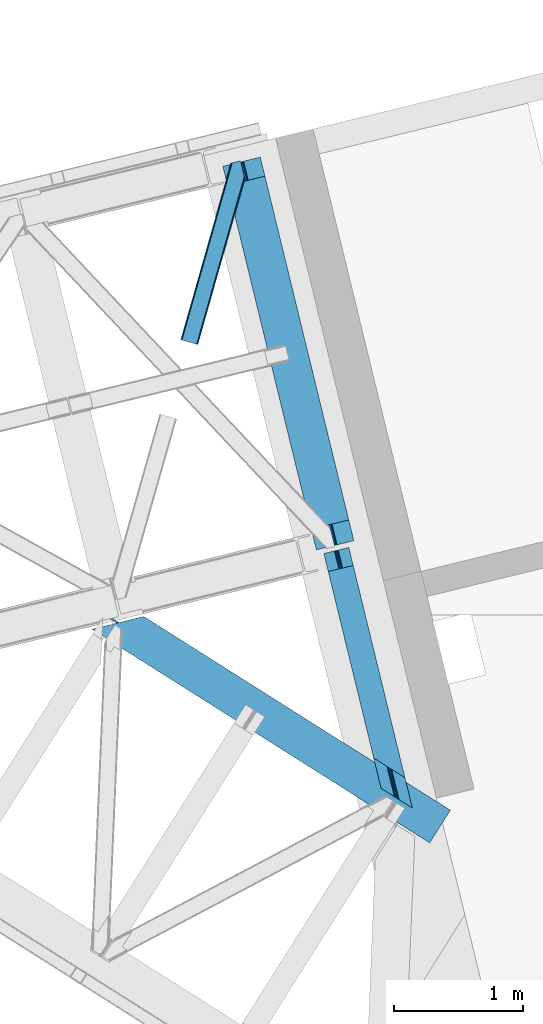
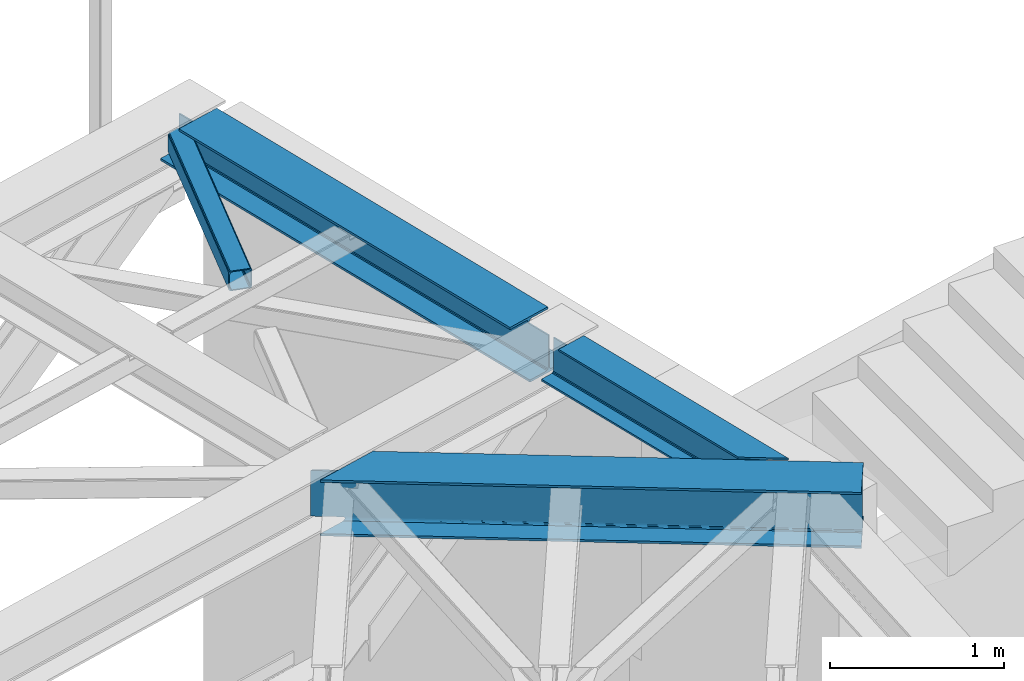
# One storey, part 62 of 66: 3 beams, 1 member.
"""IFC4 building model written with IfcOpenShell, lengths in millimetres."""

from ifc_helpers import new_model, entity, si_unit, converted_unit, derived_unit, direction, frame, origin, place, context, subcontext, project, spatial, triangles, polygons, material, type_object, element, save


model = new_model("IFC4")

# Units and contexts
model_context = context("Model", 3, precision=0.01, world=origin(), true_north=direction((6.12303176911189e-17, 1.0)))
plan_context = context("Plan", 3, precision=0.01, world=origin(), true_north=direction((6.12303176911189e-17, 1.0)))
body_context = subcontext(model_context, "Body", "Model", "MODEL_VIEW")
ifc_project = project(units=[si_unit("LENGTHUNIT", "METRE", prefix="MILLI"), si_unit("AREAUNIT", "SQUARE_METRE"), si_unit("VOLUMEUNIT", "CUBIC_METRE"), converted_unit("PLANEANGLEUNIT", "DEGREE", entity("IfcRatioMeasure", 0.0174532925199433), si_unit("PLANEANGLEUNIT", "RADIAN"), dimensions=[0, 0, 0, 0, 0, 0, 0]), si_unit("MASSUNIT", "GRAM", prefix="KILO"), derived_unit("MASSDENSITYUNIT", [(si_unit("MASSUNIT", "GRAM", prefix="KILO"), 1), (si_unit("LENGTHUNIT", "METRE"), -3)]), derived_unit("MOMENTOFINERTIAUNIT", [(si_unit("LENGTHUNIT", "METRE"), 4)]), si_unit("TIMEUNIT", "SECOND"), si_unit("FREQUENCYUNIT", "HERTZ"), si_unit("THERMODYNAMICTEMPERATUREUNIT", "DEGREE_CELSIUS"), derived_unit("THERMALTRANSMITTANCEUNIT", [(si_unit("MASSUNIT", "GRAM", prefix="KILO"), 1), (si_unit("THERMODYNAMICTEMPERATUREUNIT", "KELVIN"), -1), (si_unit("TIMEUNIT", "SECOND"), -3)]), derived_unit("VOLUMETRICFLOWRATEUNIT", [(si_unit("LENGTHUNIT", "METRE"), 3), (si_unit("TIMEUNIT", "SECOND"), -1)]), derived_unit("MASSFLOWRATEUNIT", [(si_unit("MASSUNIT", "GRAM", prefix="KILO"), 1), (si_unit("TIMEUNIT", "SECOND"), -1)]), derived_unit("ROTATIONALFREQUENCYUNIT", [(si_unit("TIMEUNIT", "SECOND"), -1)]), si_unit("ELECTRICCURRENTUNIT", "AMPERE"), si_unit("ELECTRICVOLTAGEUNIT", "VOLT"), si_unit("POWERUNIT", "WATT"), si_unit("FORCEUNIT", "NEWTON", prefix="KILO"), si_unit("ILLUMINANCEUNIT", "LUX"), si_unit("LUMINOUSFLUXUNIT", "LUMEN"), si_unit("LUMINOUSINTENSITYUNIT", "CANDELA"), derived_unit("USERDEFINED", [(si_unit("MASSUNIT", "GRAM", prefix="KILO"), -1), (si_unit("LENGTHUNIT", "METRE"), -2), (si_unit("TIMEUNIT", "SECOND"), 3), (si_unit("LUMINOUSFLUXUNIT", "LUMEN"), 1)]), derived_unit("LINEARVELOCITYUNIT", [(si_unit("LENGTHUNIT", "METRE"), 1), (si_unit("TIMEUNIT", "SECOND"), -1)]), si_unit("PRESSUREUNIT", "PASCAL"), derived_unit("USERDEFINED", [(si_unit("LENGTHUNIT", "METRE"), -2), (si_unit("MASSUNIT", "GRAM", prefix="KILO"), 1), (si_unit("TIMEUNIT", "SECOND"), -2)]), derived_unit("LINEARFORCEUNIT", [(si_unit("MASSUNIT", "GRAM", prefix="KILO"), 1), (si_unit("LENGTHUNIT", "METRE"), 1), (si_unit("TIMEUNIT", "SECOND"), -2), (si_unit("LENGTHUNIT", "METRE"), -1)]), derived_unit("PLANARFORCEUNIT", [(si_unit("MASSUNIT", "GRAM", prefix="KILO"), 1), (si_unit("LENGTHUNIT", "METRE"), 1), (si_unit("TIMEUNIT", "SECOND"), -2), (si_unit("LENGTHUNIT", "METRE"), -2)])], contexts=[model_context, plan_context])

# Site, building, storey
site_placement = place(None, origin())
site = spatial("IfcSite", under=ifc_project, at=site_placement, CompositionType="ELEMENT")
building_placement = place(site_placement, origin())
building = spatial("IfcBuilding", under=site, at=building_placement, CompositionType="ELEMENT")
storey_placement = place(building_placement, frame((0.0, 0.0, 19800.0)))
storey = spatial("IfcBuildingStorey", under=building, at=storey_placement, Name="06", CompositionType="ELEMENT", Elevation=19800.0)

# Beams
ifc_material = material(Name="Metal painted (White)")
beam_type_1 = type_object("IfcBeamType", PredefinedType="BEAM")
beam_1_placement = place(storey_placement, frame((-1343.06, 17467.54, 3807.02)))
element("IfcBeam", 1, at=beam_1_placement, inside=storey, type_object=beam_type_1, material=ifc_material, ObjectType="Steel Beam", PredefinedType="BEAM", context=body_context, shape_type="Tessellation", body=[
    polygons([(1018.1664837833, 71.0478278971021, 15.5000000000008), (1018.1664837833, 71.0478278971021, 0.0), (291.465617442453, 3052.25531830422, 0.0), (291.465617442454, 3052.25531830422, 15.5000000000008), (894.779372399333, 40.970914087327, 15.5000000000008), (168.078506058483, 3022.17840449444, 15.5000000000008), (888.087028625381, 39.3395844888265, 16.8701684147984), (161.386162284531, 3020.54707489594, 16.8701684147984), (882.413533524758, 37.9566100336519, 20.7720779386478), (155.712667183908, 3019.16410044076, 20.7720779386478), (878.622625296188, 37.0325360459184, 26.6116982174294), (151.921758955338, 3018.24002645303, 26.6116982174294), (877.291435352788, 36.7080444135029, 33.500000000001), (150.590569011938, 3017.91553482062, 33.500000000001), (140.875048430526, 3015.54727389072, 33.500000000001), (140.875048430528, 3015.54727389072, 259.000000000002), (150.590569011939, 3017.91553482062, 259.000000000002), (2.70716782324598e-13, 2981.20749040711, 0.0), (4.06075173486897e-12, 2981.20749040711, 15.4999999999965), (123.387111383982, 3011.28440421689, 15.5000000000008), (130.079455157932, 3012.91573381539, 16.8701684147898), (135.75295025856, 3014.29870827056, 20.7720779386434), (139.543858487129, 3015.2227822583, 26.6116982174294), (877.291435352789, 36.7080444135072, 259.000000000002), (867.57591477138, 34.3397834836014, 259.000000000002), (867.575914771376, 34.3397834836014, 33.500000000001), (866.244724827979, 34.0152918511859, 26.6116982174294), (862.45381659941, 33.0912178634546, 20.7720779386434), (856.780321498783, 31.70824340828, 16.8701684147898), (850.087977724833, 30.0769138097773, 15.5000000000008), (726.700866340854, 0.0, 15.4999999999965), (726.700866340851, 0.0, 0.0), (838.12452361592, 197.385937999183, 259.069791973884), (186.469722099977, 2870.72539801218, 259.000000000002), (186.693115201829, 2869.8089536072, 259.617303331124), (186.705504045456, 2869.75812937344, 266.500003008253), (837.979344808154, 197.981416001704, 266.500002998871), (837.979694928906, 197.97997969697, 260.000004007589), (828.499586345894, 194.645865944436, 259.006343171919), (828.276216326131, 195.562317481916, 259.617303331124), (828.263827482503, 195.613141715691, 266.500003008253), (176.989986719805, 2867.38985508743, 266.500002998871), (176.989636599053, 2867.39129139216, 260.000004007589), (176.844830940719, 2867.98534020595, 259.07612046749), (176.75420151856, 2868.35713708228, 259.000000000002), (839.310832678077, 198.30468544639, 273.388305639783), (843.101109266768, 199.231350618303, 279.227924098781), (848.774180214308, 200.616065081983, 283.129832400619), (855.466371895431, 202.248018612794, 284.500000377224), (978.853400583272, 232.325271667905, 284.500000138971), (978.851730776624, 232.332121736639, 299.999995328161), (687.386308679348, 161.283492472596, 299.999995890962), (687.387978486002, 161.276642403861, 284.500000701776), (810.775007173859, 191.353895458976, 284.500000463519), (817.467494069994, 192.984637925553, 283.129832461069), (823.141405718764, 194.365903570081, 279.227924137322), (826.932940505748, 195.287407219375, 273.388305663684), (175.658498849865, 2867.06658564273, 273.388305639783), (171.86822226118, 2866.13992047083, 279.227924098781), (166.195151313635, 2864.75520600714, 283.129832400619), (159.502959632511, 2863.12325247633, 284.500000377228), (36.1159309446587, 2833.04599942122, 284.500000138971), (36.1176007513048, 2833.03914935249, 299.999995328161), (327.583022848581, 2904.08777861653, 299.999995890962), (327.581353041929, 2904.09462868526, 284.500000701776), (204.194324354082, 2874.01737563015, 284.500000463519), (197.501837457949, 2872.38663316357, 283.129832461069), (191.827925809184, 2871.00536751905, 279.227924137318), (188.036391022195, 2870.08386386975, 273.388305663684)], [[[1, 2, 3, 4]], [[5, 1, 4, 6]], [[7, 5, 6, 8]], [[9, 7, 8, 10]], [[11, 9, 10, 12]], [[13, 11, 12, 14]], [[15, 16, 17, 14, 12, 10, 8, 6, 4, 3, 18, 19, 20, 21, 22, 23]], [[13, 24, 25, 26, 27, 28, 29, 30, 31, 32, 2, 1, 5, 7, 9, 11]], [[2, 32, 18, 3]], [[32, 31, 19, 18]], [[31, 30, 20, 19]], [[27, 26, 15, 23]], [[28, 27, 23, 22]], [[29, 28, 22, 21]], [[30, 29, 21, 20]], [[33, 24, 13, 14, 17, 34, 35, 36, 37, 38]], [[25, 39, 40, 41, 42, 43, 44, 16, 15, 26]], [[39, 25, 24, 33]], [[45, 34, 17, 16]], [[41, 40, 38, 37, 46, 47, 48, 49, 50, 51, 52, 53, 54, 55, 56, 57]], [[42, 58, 59, 60, 61, 62, 63, 64, 65, 66, 67, 68, 69, 36, 35, 43]], [[46, 37, 36, 69]], [[47, 46, 69, 68]], [[48, 47, 68, 67]], [[49, 48, 67, 66]], [[50, 49, 66, 65]], [[51, 50, 65, 64]], [[52, 51, 64, 63]], [[53, 52, 63, 62]], [[54, 53, 62, 61]], [[55, 54, 61, 60]], [[56, 55, 60, 59]], [[57, 56, 59, 58]], [[41, 57, 58, 42]]], closed=False),
])
beam_2_placement = place(storey_placement, frame((-557.96, 15460.66, 3813.0)))
element("IfcBeam", 2, at=beam_2_placement, inside=storey, type_object=beam_type_1, material=ifc_material, ObjectType="Steel Beam", PredefinedType="BEAM", context=body_context, shape_type="Tessellation", body=[
    polygons([(503.901998279631, 315.50898790348, 264.000000000001), (502.234787414298, 316.562983810857, 270.888301782572), (125.857083537508, 1860.60962251877, 270.888301782572), (127.188273480905, 1860.93411415118, 264.000000000001), (497.486972559246, 319.564510210594, 276.727922061363), (122.066175308936, 1859.68554853103, 276.727922061363), (490.381365487108, 324.056611917234, 280.629831585203), (116.392680208322, 1858.30257407586, 280.629831585203), (481.999730462124, 329.355407166941, 282.000000000001), (109.700336434367, 1856.67124447736, 282.000000000001), (387.394101417021, 389.164245929956, 282.000000000001), (34.1621639138618, 1838.25801574736, 282.000000000001), (387.394101417016, 389.164245929958, 294.999999999994), (34.1621639138565, 1838.25801574736, 294.999999999994), (135.446465975099, 1862.9471359416, 258.999999999997), (127.188273480905, 1860.93411415118, 258.999999999997), (228.472575542141, 1885.62323434542, 294.999999999998), (228.472575542145, 1885.62323434542, 281.999999999997), (152.934403021655, 1867.21000561543, 282.000000000001), (146.24205924769, 1865.57867601692, 280.629831585203), (140.56856414708, 1864.19570156175, 276.727922061358), (136.777655918495, 1863.27162757401, 270.888301782572), (135.4464659751, 1862.9471359416, 264.000000000001), (514.244735860121, 308.970401029069, 255.000000000003), (514.244735860121, 308.970401029069, 264.000000000001), (515.911946725451, 307.916405121688, 270.888301782572), (520.659761580513, 304.914878721951, 276.727922061358), (527.76536865265, 300.422777015311, 280.629831585203), (536.14700367764, 295.123981765602, 282.000000000001), (630.752632722732, 235.31514300259, 281.999999999997), (630.752632722729, 235.31514300259, 294.999999999998), (503.901998279631, 315.50898790348, 255.000000000003), (93.0261095670512, 2001.08049853809, 258.999999999997), (93.0261095670512, 2001.08049853809, 30.9999999999973), (561.262553971507, 80.1938449016465, 30.9999999999973), (561.262553971513, 80.1938449016551, 253.999999999999), (504.242922830551, 314.110383784594, 253.999999999999), (101.284302061246, 2003.09352032851, 30.9999999999973), (101.284302061246, 2003.09352032851, 258.999999999997), (514.58566041104, 307.571796910181, 253.999999999999), (571.605291551999, 73.65525802724, 253.999999999999), (571.605291551993, 73.6552580272313, 30.9999999999973), (444.754657108931, 153.849102928183, 0.0), (688.113188415015, 1.99247551790904e-10, 0.0), (688.113188415522, 4.98118879477261e-11, 13.0000000000014), (593.507559369495, 59.8088387637354, 13.0000000000014), (585.125924344507, 65.1076340134534, 14.370168414799), (578.020317272372, 69.5997357200954, 18.2720779386353), (573.272502417317, 72.6012621198371, 24.11169821743), (559.595343106168, 81.2478408090147, 24.1116982174213), (554.847528251111, 84.2493672087563, 18.2720779386353), (547.741921178978, 88.7414689153962, 14.3701684147947), (539.360286153997, 94.0402641651099, 13.0000000000014), (444.754657108934, 153.849102928187, 13.0000000000014), (102.615492004642, 2003.41801196092, 24.1116982174213), (106.406400233223, 2004.34208594866, 18.2720779386353), (112.079895333836, 2005.72506040383, 14.370168414799), (118.7722391078, 2007.35639000234, 13.0000000000014), (194.310411628288, 2025.76961873233, 13.0000000000014), (194.310411628358, 2025.76961873235, 0.0), (7.44471151392645e-13, 1978.40440013427, 0.0), (3.65467656138208e-12, 1978.40440013427, 13.0000000000014), (75.5381725205065, 1996.81762886426, 13.0000000000014), (82.2305162944635, 1998.44895846277, 14.3701684147947), (87.9040113950731, 1999.83193291794, 18.2720779386353), (91.6949196236502, 2000.75600690567, 24.1116982174213)], [[[1, 2, 3, 4]], [[2, 5, 6, 3]], [[5, 7, 8, 6]], [[7, 9, 10, 8]], [[11, 12, 10, 9]], [[13, 14, 12, 11]], [[15, 16, 4, 3, 6, 8, 10, 12, 14, 17, 18, 19, 20, 21, 22, 23]], [[24, 25, 26, 27, 28, 29, 30, 31, 13, 11, 9, 7, 5, 2, 1, 32]], [[31, 17, 14, 13]], [[30, 18, 17, 31]], [[29, 19, 18, 30]], [[29, 28, 20, 19]], [[28, 27, 21, 20]], [[27, 26, 22, 21]], [[26, 25, 23, 22]], [[4, 16, 33, 34, 35, 36, 37, 32, 1]], [[38, 39, 15, 23, 25, 24, 40, 41, 42]], [[39, 33, 16, 15]], [[41, 40, 37, 36]], [[43, 44, 45, 46, 47, 48, 49, 42, 41, 36, 35, 50, 51, 52, 53, 54]], [[39, 38, 55, 56, 57, 58, 59, 60, 61, 62, 63, 64, 65, 66, 34, 33]], [[42, 49, 55, 38]], [[49, 48, 56, 55]], [[48, 47, 57, 56]], [[47, 46, 58, 57]], [[46, 45, 59, 58]], [[60, 59, 45, 44]], [[53, 52, 64, 63]], [[52, 51, 65, 64]], [[51, 50, 66, 65]], [[50, 35, 34, 66]], [[54, 53, 63, 62]], [[43, 54, 62, 61]], [[44, 43, 61, 60]]], closed=False),
])
beam_type_2 = type_object("IfcBeamType", PredefinedType="BEAM")
beam_3_placement = place(storey_placement, frame((-2362.12, 15190.28, 3716.0)))
element("IfcBeam", 3, at=beam_3_placement, inside=storey, type_object=beam_type_2, ObjectType="Steel Beam", PredefinedType="BEAM", context=body_context, shape_type="Tessellation", body=[
    triangles([(25.3249076843263, 1815.17176208496, 36.0001281738296), (40.9816555023194, 1818.98780822754, 36.0001281738296), (181.779747390747, 1716.15803833008, 36.0001281738296), (197.558580780029, 1720.00431518555, 36.0001281738296), (207.42120552063, 1714.40233154297, 32.7793945312515), (211.844627380371, 1713.10473632813, 29.1912414550789), (191.366516876221, 1708.03411560059, 29.2098449707046), (190.191879272461, 1710.20258789062, 32.7793945312515), (189.084098052978, 1706.61559753418, 25.0007995605483), (216.100762939453, 1713.20124206543, 25.0007995605483), (202.62673072815, 1716.90682983398, 35.1629699707046), (186.599365997315, 1713.00009155273, 35.1629699707046), (2710.74209747314, 133.063970947265, 29.5819152832046), (2713.28772697449, 137.095120239257, 22.4451416015654), (219.060320663452, 1713.92329101562, 22.4451416015654), (2709.84731197357, 131.648941040039, 38.0000061035171), (40.8597152709963, 1818.95874023438, 38.0000061035171), (2717.10202903748, 143.127310180664, 17.6756652832046), (228.703046035766, 1716.27314758301, 17.6756652832046), (2721.60019197464, 150.244317626953, 16.0013488769546), (240.071683502197, 1719.04507141113, 16.0013488769546), (405.184860992432, 1759.29261474609, 16.0013488769546), (2786.92556505203, 253.576382446288, 16.0013488769546), (2786.92556505203, 253.576382446288, 0.0), (405.184860992432, 1759.29261474609, 0.0), (0.0, 1660.52422485351, 0.0), (2626.6178355217, 0.0, 0.0), (165.113177490234, 1700.7729309082, 16.0013488769546), (0.0, 1660.52422485351, 16.0013488769546), (176.486320495605, 1703.54485473633, 17.6756652832046), (186.124540328979, 1705.89471130371, 22.4451416015654), (2626.6178355217, 0.0, 16.0013488769546), (2691.94328126907, 103.332064819337, 16.0013488769546), (2703.70066680908, 121.928604125977, 38.0000061035171), (25.3249076843263, 1815.17176208496, 38.0000061035171), (2702.80588130951, 120.512411499023, 29.5819152832046), (2700.25570993423, 116.481262207031, 22.4451416015654), (2696.44137153625, 110.447909545899, 17.6756652832046), (2709.84731197357, 131.648941040039, 354.001647949219), (40.8597152709963, 1818.95874023438, 354.001647949219), (2703.70066680908, 121.928604125977, 354.001647949219), (25.3249076843263, 1815.17176208496, 354.001647949219), (25.2766548156737, 1815.09502258301, 356.001525878906), (40.9816555023194, 1818.98780822754, 356.001525878906), (181.779747390747, 1716.15803833008, 356.001525878906), (197.558580780029, 1720.00431518555, 356.001525878906), (202.62673072815, 1716.90682983398, 356.838684082031), (186.599365997315, 1713.00009155273, 356.838684082031), (207.42120552063, 1714.40233154297, 359.222259521484), (190.191879272461, 1710.20258789062, 359.222259521484), (211.849278259278, 1713.02683410644, 362.791809082031), (191.366516876221, 1708.03411560059, 362.791809082031), (216.100762939453, 1713.20124206543, 367.000854492188), (189.084098052978, 1706.61559753418, 367.000854492188), (2710.74209747314, 133.063970947265, 362.419738769531), (2713.28772697449, 137.095120239257, 369.556512451174), (219.060320663452, 1713.92329101562, 369.556512451174), (2721.60019197464, 150.244317626953, 376.000305175781), (2717.10202903748, 143.127310180664, 374.325988769531), (240.071683502197, 1719.04507141113, 376.000305175781), (228.703046035766, 1716.27314758301, 374.325988769531), (2702.80588130951, 120.512411499023, 362.419738769531), (2700.25570993423, 116.481262207031, 369.556512451174), (186.124540328979, 1705.89471130371, 369.556512451174), (2696.44137153625, 110.447909545899, 374.325988769531), (176.486320495605, 1703.54485473633, 374.325988769531), (2691.94328126907, 103.332064819337, 376.000305175781), (165.113177490234, 1700.7729309082, 376.000305175781), (405.184860992432, 1759.29261474609, 376.000305175781), (2786.92556505203, 253.576382446288, 376.000305175781), (2786.92556505203, 253.576382446288, 392.001654052736), (405.184860992432, 1759.29261474609, 392.001654052736), (2626.6178355217, 0.0, 392.001654052736), (2626.6178355217, 0.0, 376.000305175781), (0.0, 1660.52422485351, 392.001654052736), (0.0, 1660.52422485351, 376.000305175781)], [[1, 2, 3], [4, 3, 2], [5, 6, 7], [7, 8, 5], [9, 7, 6], [6, 10, 9], [11, 5, 8], [8, 12, 11], [4, 11, 12], [12, 3, 4], [13, 14, 15], [15, 10, 13], [16, 11, 4], [4, 17, 16], [4, 2, 17], [16, 13, 6], [6, 5, 16], [5, 11, 16], [10, 6, 13], [14, 18, 19], [19, 15, 14], [18, 20, 21], [21, 19, 18], [22, 21, 20], [20, 23, 22], [23, 24, 25], [25, 22, 23], [26, 25, 27], [24, 27, 25], [26, 28, 21], [29, 28, 26], [21, 28, 19], [21, 25, 26], [22, 25, 21], [19, 28, 30], [30, 31, 15], [31, 9, 10], [10, 15, 31], [15, 19, 30], [28, 29, 32], [32, 33, 28], [27, 32, 26], [29, 26, 32], [34, 35, 3], [3, 36, 34], [3, 12, 36], [35, 1, 3], [12, 8, 36], [8, 7, 36], [37, 7, 9], [7, 37, 36], [9, 31, 37], [33, 38, 30], [30, 28, 33], [38, 37, 31], [31, 30, 38], [39, 16, 17], [17, 40, 39], [34, 41, 35], [42, 35, 41], [40, 42, 17], [43, 42, 40], [40, 44, 43], [17, 42, 35], [35, 1, 17], [2, 17, 1], [44, 43, 45], [45, 46, 44], [47, 46, 48], [45, 48, 46], [49, 47, 50], [48, 50, 47], [51, 49, 52], [50, 52, 49], [53, 51, 54], [52, 54, 51], [55, 47, 49], [39, 40, 46], [46, 55, 39], [46, 47, 55], [40, 44, 46], [49, 51, 55], [56, 51, 53], [51, 56, 55], [53, 57, 56], [58, 59, 60], [61, 60, 59], [59, 56, 61], [57, 61, 56], [41, 48, 45], [41, 50, 48], [45, 42, 41], [45, 43, 42], [41, 62, 52], [52, 50, 41], [63, 64, 54], [54, 62, 63], [54, 52, 62], [63, 65, 64], [66, 64, 65], [65, 67, 66], [68, 66, 67], [60, 69, 58], [70, 58, 69], [71, 70, 69], [69, 72, 71], [16, 39, 41], [56, 59, 65], [58, 71, 73], [70, 71, 58], [59, 58, 67], [39, 55, 62], [55, 56, 63], [14, 38, 18], [24, 20, 27], [20, 18, 33], [24, 23, 20], [14, 13, 37], [13, 16, 36], [34, 16, 41], [67, 65, 59], [62, 55, 63], [65, 63, 56], [62, 41, 39], [73, 67, 58], [73, 74, 67], [33, 18, 38], [37, 13, 36], [34, 36, 16], [37, 38, 14], [33, 27, 20], [27, 33, 32], [61, 66, 68], [54, 64, 53], [64, 66, 57], [61, 57, 66], [57, 53, 64], [68, 75, 60], [75, 68, 76], [72, 60, 75], [68, 60, 61], [72, 69, 60], [72, 75, 73], [73, 71, 72], [74, 73, 76], [75, 76, 73], [76, 68, 74], [67, 74, 68]]),
])

# Member
member_type = type_object("IfcMemberType", PredefinedType="BRACE")
member_placement = place(storey_placement, frame((-1671.07, 19062.47, 3823.02)))
element("IfcMember", 4, at=member_placement, inside=storey, type_object=member_type, ObjectType="Steel Horizontal Brace", PredefinedType="BRACE", context=body_context, shape_type="Tessellation", body=[
    triangles([(500.301584243774, 1287.51443481445, 17.4989318847656), (500.301584243774, 1287.51443481445, 122.499499511716), (134.676372528076, 0.0, 17.4989318847656), (134.676372528076, 0.0, 122.499499511716), (495.114400863647, 1308.79453125, 138.668280029295), (491.898754119873, 1321.98674926758, 139.998431396481), (117.842952346802, 4.77994079589553, 139.998431396481), (124.282530212402, 2.94981994628688, 138.668280029295), (497.840469932556, 1297.61149291992, 134.873162841795), (129.74440612793, 1.39991455078052, 134.873162841795), (499.662015724182, 1290.13985595703, 129.196765136716), (133.395636749268, 0.363931274412607, 129.196765136716), (16.8379257202148, 33.4642364501924, 139.998431396481), (409.260048294067, 1415.34616699219, 139.998431396481), (465.782761001587, 1429.12439575195, 139.998431396481), (391.19923210144, 1410.94411010742, 129.196765136716), (389.71269493103, 1410.58134155273, 122.499499511716), (1.28073577880855, 37.880245971679, 129.196765136716), (0.0, 38.2441772460916, 122.499499511716), (395.437636184692, 1411.97660522461, 134.873162841795), (4.93196640014662, 36.844262695311, 134.873162841795), (401.777220153809, 1413.52302246094, 138.668280029295), (10.393842315674, 35.2931945800774, 138.668280029295), (389.71269493103, 1410.58134155273, 17.4989318847656), (0.0, 38.2441772460916, 17.4989318847656), (1.28073577880855, 37.880245971679, 10.8016662597656), (391.19923210144, 1410.94411010742, 10.8016662597656), (350.625400543213, 1255.50010986328, 5.49966430664063), (4.93196640014662, 36.844262695311, 5.12526855468604), (350.610866546631, 1254.51877441406, 5.25084228515334), (395.030974960327, 1411.87893676758, 5.49966430664063), (350.591681671143, 1253.51883544922, 4.99969482421875), (10.393842315674, 35.2931945800774, 1.33247680663771), (350.577002334595, 1252.51657104492, 4.74622192382594), (350.562613677979, 1251.53756103515, 4.49972534179688), (352.972204971313, 1241.65211791992, 1.33247680663771), (356.187851715088, 1228.45989990234, 0.0), (16.8379257202148, 33.4642364501924, 0.0), (386.342987823486, 1104.751171875, 0.0), (117.842952346802, 4.77994079589553, 0.0), (433.47165184021, 1116.23884277344, 0.0), (447.69621963501, 1119.70607299804, 5.49966430664063), (440.949974441528, 1118.06198730469, 1.33247680663771), (387.314440155029, 1104.98836669922, 5.49966430664063), (386.342987823486, 1104.751171875, 4.49972534179688), (498.721520805359, 1286.82843017578, 10.8016662597656), (133.395636749268, 0.363931274412607, 10.8016662597656), (129.74440612793, 1.39991455078052, 5.12526855468604), (124.282530212402, 2.94981994628688, 1.33247680663771), (494.138297653198, 1283.24260253906, 5.49966430664063), (499.951314926147, 1288.95155639648, 12.4992370605469), (458.982304000855, 1427.46635742187, 5.49966430664063), (494.653818511963, 1310.68511352539, 12.4992370605469), (489.445488166809, 1314.45465087891, 8.33204956054396), (485.489479637146, 1325.04702758789, 6.99957275390625), (460.437302398682, 1427.8221496582, 6.99957275390625), (23.5703636169435, 31.5515624999971, 6.99957275390625), (417.077158355713, 1417.2507019043, 6.99957275390625), (111.110514450073, 6.69261474609084, 6.99957275390625), (496.300883674622, 1303.92738647461, 17.8035644531228), (123.011968231201, 3.31258850097583, 12.1248413085923), (126.663198852539, 2.27660522460792, 17.8035644531228), (496.940452194214, 1301.30429077148, 24.4985046386719), (127.943934631348, 1.91151123046802, 24.4985046386719), (117.550092315674, 4.86249389648219, 8.33204956054396), (496.940452194214, 1301.30429077148, 115.49992675781), (127.943934631348, 1.91151123046802, 115.49992675781), (496.300883674622, 1303.92738647461, 122.19719238281), (494.479337882996, 1311.3990234375, 127.873590087889), (491.75334148407, 1322.58206176758, 131.666381835938), (488.537622070313, 1335.77427978515, 132.998858642575), (465.782761001587, 1429.12439575195, 132.998858642575), (126.663198852539, 2.27660522460792, 122.19719238281), (123.011968231201, 3.31258850097583, 127.873590087889), (117.550092315674, 4.86249389648219, 131.666381835938), (111.110514450073, 6.69261474609084, 132.998858642575), (23.5703636169435, 31.5515624999971, 132.998858642575), (417.077158355713, 1417.2507019043, 132.998858642575), (11.6645496368408, 34.9315887451157, 127.873590087889), (17.1264255523681, 33.3805206298821, 131.666381835938), (6.73694343566899, 36.3326660156235, 115.49992675781), (8.01767921447754, 35.9687347412109, 122.19719238281), (11.6645496368408, 34.9315887451157, 12.1248413085923), (17.1264255523681, 33.3805206298821, 8.33204956054396), (6.73694343566899, 36.3326660156235, 24.4985046386719), (8.01767921447754, 35.9687347412109, 17.8035644531228), (409.598835754394, 1415.4298828125, 131.666381835938), (403.254746246338, 1413.88346557617, 127.873590087889), (399.020847702026, 1412.85097045898, 122.19719238281), (397.529804992676, 1412.48587646484, 115.49992675781), (409.598835754394, 1415.4298828125, 8.33204956054396), (399.020847702026, 1412.85097045898, 17.8035644531228), (403.254746246338, 1413.88346557617, 12.1248413085923), (397.529804992676, 1412.48587646484, 24.4985046386719)], [[1, 2, 3], [4, 3, 2], [5, 6, 7], [7, 8, 5], [9, 5, 8], [8, 10, 9], [11, 9, 10], [10, 12, 11], [2, 11, 12], [12, 4, 2], [13, 6, 14], [13, 7, 6], [6, 15, 14], [16, 17, 18], [19, 18, 17], [20, 16, 21], [18, 21, 16], [22, 20, 23], [21, 23, 20], [14, 22, 13], [23, 13, 22], [17, 24, 19], [25, 19, 24], [26, 27, 28], [28, 29, 26], [28, 30, 29], [27, 31, 28], [32, 33, 29], [32, 34, 33], [35, 33, 34], [35, 36, 33], [36, 37, 33], [38, 33, 37], [24, 27, 26], [26, 25, 24], [39, 38, 37], [40, 39, 41], [39, 40, 38], [41, 42, 43], [41, 39, 44], [41, 44, 42], [44, 39, 45], [30, 28, 44], [34, 32, 44], [35, 34, 45], [37, 35, 45], [37, 36, 35], [45, 39, 37], [46, 1, 3], [3, 47, 46], [48, 49, 43], [47, 48, 42], [50, 46, 42], [47, 42, 46], [43, 42, 48], [41, 43, 49], [49, 40, 41], [46, 51, 1], [42, 28, 50], [42, 44, 28], [31, 50, 28], [52, 50, 31], [53, 50, 54], [51, 46, 53], [53, 46, 50], [55, 50, 52], [50, 55, 54], [52, 56, 55], [57, 55, 58], [57, 59, 55], [55, 56, 58], [60, 53, 61], [61, 62, 60], [63, 60, 62], [62, 64, 63], [54, 55, 59], [59, 65, 54], [53, 54, 65], [65, 61, 53], [66, 63, 67], [64, 67, 63], [60, 51, 53], [2, 1, 63], [1, 60, 63], [63, 66, 2], [1, 51, 60], [68, 2, 66], [11, 2, 68], [9, 68, 69], [68, 9, 11], [69, 5, 9], [70, 5, 69], [70, 71, 6], [70, 6, 5], [71, 15, 6], [71, 72, 15], [68, 66, 73], [67, 73, 66], [69, 68, 74], [73, 74, 68], [70, 69, 75], [74, 75, 69], [71, 70, 76], [75, 76, 70], [77, 71, 76], [71, 77, 78], [72, 71, 78], [12, 74, 73], [67, 3, 4], [12, 73, 4], [12, 10, 74], [73, 67, 4], [74, 10, 8], [76, 7, 13], [7, 75, 8], [75, 7, 76], [75, 74, 8], [47, 61, 48], [64, 3, 67], [3, 62, 47], [62, 3, 64], [47, 62, 61], [40, 59, 38], [49, 48, 61], [61, 65, 49], [65, 59, 40], [40, 49, 65], [79, 23, 21], [13, 77, 76], [13, 80, 77], [80, 13, 23], [79, 80, 23], [81, 19, 25], [18, 82, 79], [21, 18, 79], [82, 18, 19], [81, 82, 19], [33, 83, 29], [38, 59, 57], [57, 84, 38], [84, 83, 33], [33, 38, 84], [26, 29, 83], [25, 85, 81], [86, 25, 26], [25, 86, 85], [86, 26, 83], [22, 14, 87], [15, 78, 14], [78, 15, 72], [78, 87, 14], [88, 22, 87], [88, 20, 22], [16, 88, 89], [88, 16, 20], [17, 89, 90], [89, 17, 16], [58, 31, 91], [92, 93, 27], [93, 91, 31], [58, 52, 31], [52, 58, 56], [94, 92, 24], [27, 24, 92], [17, 94, 24], [94, 17, 90], [93, 31, 27], [87, 78, 77], [77, 80, 87], [88, 87, 80], [80, 79, 88], [89, 88, 79], [79, 82, 89], [90, 89, 82], [82, 81, 90], [94, 90, 85], [81, 85, 90], [92, 94, 86], [85, 86, 94], [93, 92, 83], [86, 83, 92], [91, 93, 84], [83, 84, 93], [58, 91, 57], [84, 57, 91]]),
])

save(model, "model.ifc")
